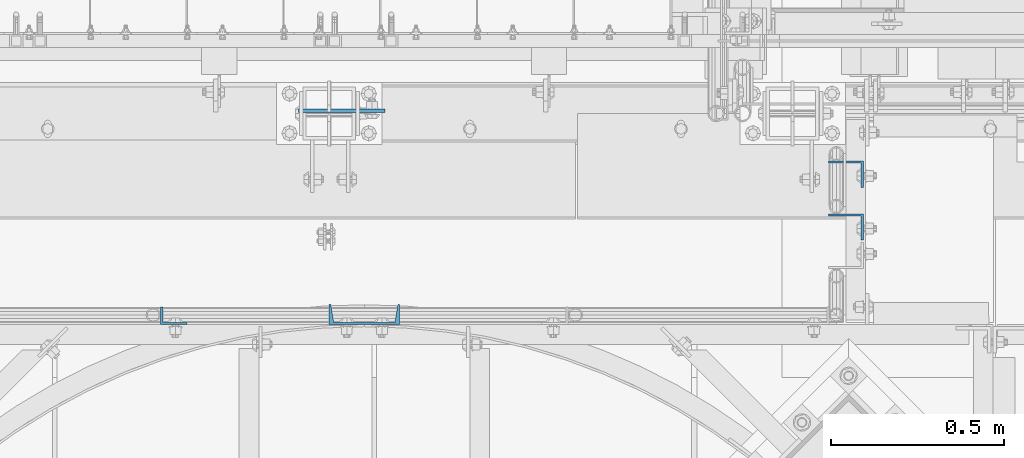
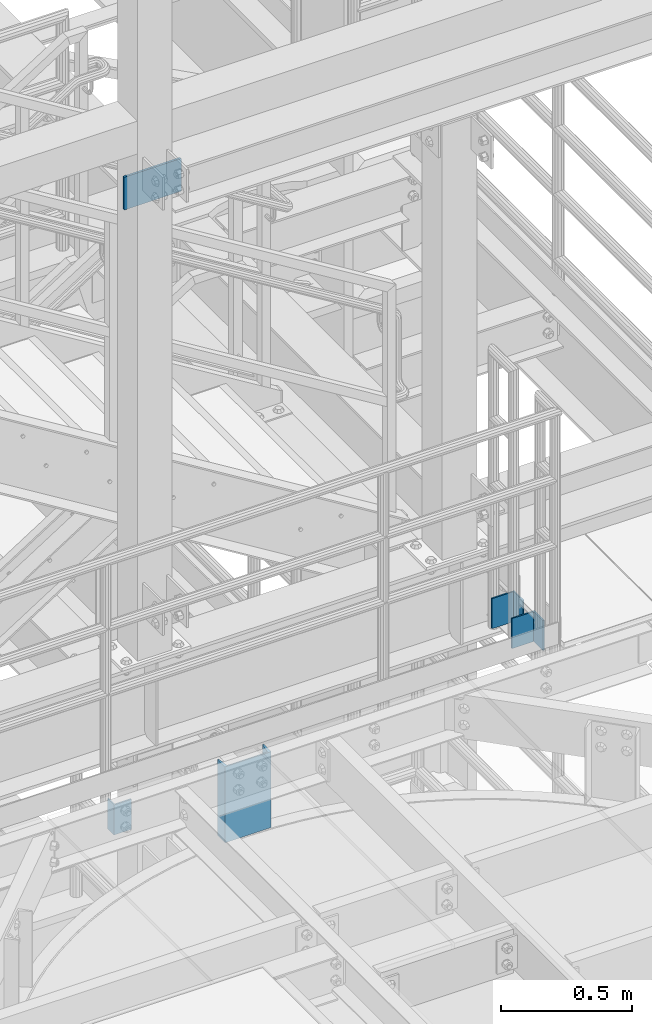
# One storey, part 811 of 1876: 5 columns, 4 elements without a shape of their own.
"""IFC2X3 building model written with IfcOpenShell, lengths in millimetres."""

from ifc_helpers import new_model, si_unit, frame, origin_with_axes, place, context, subcontext, project, spatial, faceted_brep, material, type_object, element, aggregate, save


model = new_model("IFC2X3")

# Units and contexts
model_context = context("Model", 3, precision=1e-05, world=origin_with_axes())
body_context = subcontext(model_context, "Body", "Model", "MODEL_VIEW")
ifc_project = project(units=[si_unit("LENGTHUNIT", "METRE", prefix="MILLI"), si_unit("AREAUNIT", "SQUARE_METRE"), si_unit("VOLUMEUNIT", "CUBIC_METRE"), si_unit("MASSUNIT", "GRAM", prefix="KILO"), si_unit("TIMEUNIT", "SECOND"), si_unit("PLANEANGLEUNIT", "RADIAN"), si_unit("SOLIDANGLEUNIT", "STERADIAN"), si_unit("THERMODYNAMICTEMPERATUREUNIT", "DEGREE_CELSIUS"), si_unit("LUMINOUSINTENSITYUNIT", "LUMEN")], contexts=[model_context])

# Site, building, storey
site_placement = place(None, origin_with_axes())
site = spatial("IfcSite", under=ifc_project, at=site_placement, CompositionType="ELEMENT")
building_placement = place(site_placement, origin_with_axes())
building = spatial("IfcBuilding", under=site, at=building_placement, Name="Undefined", CompositionType="ELEMENT")
storey_placement = place(building_placement, origin_with_axes())
storey = spatial("IfcBuildingStorey", under=building, at=storey_placement, Name="Undefined", CompositionType="ELEMENT", Elevation=0.0)

# Assembly, columns
assembly_1_placement = place(storey_placement, origin_with_axes())
assembly_1 = element("IfcElementAssembly", 1, at=assembly_1_placement, inside=storey, Name="RAIL", AssemblyPlace="NOTDEFINED", PredefinedType="RIGID_FRAME")
ifc_material = material(Name="STEEL/A36")
column_type_1 = type_object("IfcColumnType", Name="L4X3X1/4", PredefinedType="NOTDEFINED")
column_1_placement = place(assembly_1_placement, frame((6572.25, -7287.38315429563, 7826.375), z_axis=(-1.0, 0.0, 0.0), x_axis=(0.0, 0.0, 1.0)))
column_1 = element("IfcColumn", 2, at=column_1_placement, type_object=column_type_1, material=ifc_material, Name="ANGLE", ObjectType="L4X3X1/4", context=body_context, shape_type="Brep", body=[
    faceted_brep([(0.0, 38.1000000000004, -50.8000000000002), (0.0, 38.1000000000004, 50.8000000000002), (139.7, 38.1000000000004, 50.8000000000002), (139.7, 38.1000000000004, -50.8000000000002), (0.0, 31.75, 50.8000000000002), (139.7, 31.75, 50.8000000000002), (0.0, 31.75, -44.4499999999998), (139.7, 31.75, -44.4499999999998), (0.0, -38.1000000000004, -44.4499999999998), (139.7, -38.1000000000004, -44.4499999999998), (0.0, -38.1000000000004, -50.8000000000002), (139.7, -38.1000000000004, -50.8000000000002)], [[[0, 1, 2, 3]], [[1, 4, 5, 2]], [[4, 6, 7, 5]], [[6, 8, 9, 7]], [[8, 10, 11, 9]], [[10, 0, 3, 11]], [[5, 7, 9, 11, 3, 2]], [[10, 8, 6, 4, 1, 0]]]),
])
column_2_placement = place(assembly_1_placement, frame((6572.25, -7439.78315429563, 7826.375), z_axis=(-1.0, 0.0, 0.0), x_axis=(0.0, 0.0, 1.0)))
column_2 = element("IfcColumn", 3, at=column_2_placement, type_object=column_type_1, material=ifc_material, Name="ANGLE", ObjectType="L4X3X1/4", context=body_context, shape_type="Brep", body=[
    faceted_brep([(0.0, 38.1000000000004, -50.8000000000002), (0.0, 38.1000000000004, 50.8000000000002), (139.7, 38.1000000000004, 50.8000000000002), (139.7, 38.1000000000004, -50.8000000000002), (0.0, 31.75, 50.8000000000002), (139.7, 31.75, 50.8000000000002), (0.0, 31.75, -44.4499999999998), (139.7, 31.75, -44.4499999999998), (0.0, -38.1000000000004, -44.4499999999998), (139.7, -38.1000000000004, -44.4499999999998), (0.0, -38.1000000000004, -50.8000000000002), (139.7, -38.1000000000004, -50.8000000000002)], [[[0, 1, 2, 3]], [[1, 4, 5, 2]], [[4, 6, 7, 5]], [[6, 8, 9, 7]], [[8, 10, 11, 9]], [[10, 0, 3, 11]], [[5, 7, 9, 11, 3, 2]], [[10, 8, 6, 4, 1, 0]]]),
])
aggregate(assembly_1, [column_1, column_2])

# Assembly, column
assembly_2_placement = place(storey_placement, origin_with_axes())
assembly_2 = element("IfcElementAssembly", 4, at=assembly_2_placement, inside=storey, Name="HANDRAIL", AssemblyPlace="NOTDEFINED", PredefinedType="RIGID_FRAME")
column_type_2 = type_object("IfcColumnType", Name="L3X2X1/4", PredefinedType="NOTDEFINED")
column_3_placement = place(assembly_2_placement, frame((4631.18674593762, -7696.16440429563, 7826.375), z_axis=(1.0, 0.0, 0.0), x_axis=(0.0, 0.0, 1.0)))
column_3 = element("IfcColumn", 5, at=column_3_placement, type_object=column_type_2, material=ifc_material, Name="ANGLE", ObjectType="L3X2X1/4", context=body_context, shape_type="Brep", body=[
    faceted_brep([(0.0, 25.3999999999996, -38.1000000000004), (0.0, 25.3999999999996, 38.1000000000004), (139.7, 25.3999999999996, 38.1000000000004), (139.7, 25.3999999999996, -38.1000000000004), (0.0, 19.0500000000002, 38.1000000000004), (139.7, 19.0500000000002, 38.1000000000004), (0.0, 19.0500000000002, -31.75), (139.7, 19.0500000000002, -31.75), (0.0, -25.3999999999996, -31.75), (139.7, -25.3999999999996, -31.75), (0.0, -25.3999999999996, -38.1000000000004), (139.7, -25.3999999999996, -38.1000000000004)], [[[0, 1, 2, 3]], [[1, 4, 5, 2]], [[4, 6, 7, 5]], [[6, 8, 9, 7]], [[8, 10, 11, 9]], [[10, 0, 3, 11]], [[5, 7, 9, 11, 3, 2]], [[10, 8, 6, 4, 1, 0]]]),
])
aggregate(assembly_2, [column_3])

assembly_3_placement = place(storey_placement, origin_with_axes())
assembly_3 = element("IfcElementAssembly", 6, at=assembly_3_placement, inside=storey, Name="FRAME", AssemblyPlace="NOTDEFINED", PredefinedType="RIGID_FRAME")
column_type_3 = type_object("IfcColumnType", PredefinedType="NOTDEFINED")
column_4_placement = place(assembly_3_placement, frame((5116.5125, -7104.06250004768, 10217.15), z_axis=(-1.0, 0.0, 0.0), x_axis=(0.0, 0.0, 1.0)))
column_4 = element("IfcColumn", 7, at=column_4_placement, type_object=column_type_3, material=ifc_material, Name="PLATE", context=body_context, shape_type="Brep", body=[
    faceted_brep([(0.0, 4.76249999999982, -125.4125), (0.0, 4.76249999999982, 125.4125), (152.4, 4.76249999999982, 125.4125), (152.4, 4.76249999999982, -125.4125), (0.0, -4.76249999999982, 125.4125), (152.4, -4.76249999999982, 125.4125), (0.0, -4.76249999999982, -125.4125), (152.4, -4.76249999999982, -125.4125)], [[[0, 1, 2, 3]], [[1, 4, 5, 2]], [[4, 6, 7, 5]], [[6, 0, 3, 7]], [[5, 7, 3, 2]], [[6, 4, 1, 0]]]),
])
aggregate(assembly_3, [column_4])

assembly_4_placement = place(storey_placement, origin_with_axes())
assembly_4 = element("IfcElementAssembly", 8, at=assembly_4_placement, inside=storey, Name="BEAM", AssemblyPlace="NOTDEFINED", PredefinedType="RIGID_FRAME")
column_type_4 = type_object("IfcColumnType", Name="C8X11.5", PredefinedType="NOTDEFINED")
column_5_placement = place(assembly_4_placement, frame((5181.6033144364, -7692.98940429495, 7620.01566278096), z_axis=(1.0, 0.0, 0.0), x_axis=(0.0, 0.0, 1.0)))
column_5 = element("IfcColumn", 9, at=column_5_placement, type_object=column_type_4, material=ifc_material, Name="BEAM", ObjectType="C8X11.5", context=body_context, shape_type="Brep", body=[
    faceted_brep([(0.0, 28.5749999999998, -101.6), (0.0, 28.5749999999998, 101.6), (352.425, 28.5749999999998, 101.6), (352.425, 28.5749999999998, -101.6), (0.0, -28.5749999999998, 101.6), (352.425, -28.5749999999998, 101.6), (0.0, -28.5749999999998, 96.8355950000005), (352.425, -28.5749999999998, 96.8355950000005), (0.0, 22.2250000000004, 88.3723150000005), (352.425, 22.2250000000004, 88.3723150000005), (0.0, 22.2250000000004, -88.3723150000005), (352.425, 22.2250000000004, -88.3723150000005), (0.0, -28.5749999999998, -96.8355950000005), (352.425, -28.5749999999998, -96.8355950000005), (0.0, -28.5749999999998, -101.6), (352.425, -28.5749999999998, -101.6)], [[[0, 1, 2, 3]], [[1, 4, 5, 2]], [[4, 6, 7, 5]], [[6, 8, 9, 7]], [[8, 10, 11, 9]], [[10, 12, 13, 11]], [[12, 14, 15, 13]], [[14, 0, 3, 15]], [[5, 7, 9, 11, 13, 15, 3, 2]], [[14, 12, 10, 8, 6, 4, 1, 0]]]),
])
aggregate(assembly_4, [column_5])

save(model, "model.ifc")
